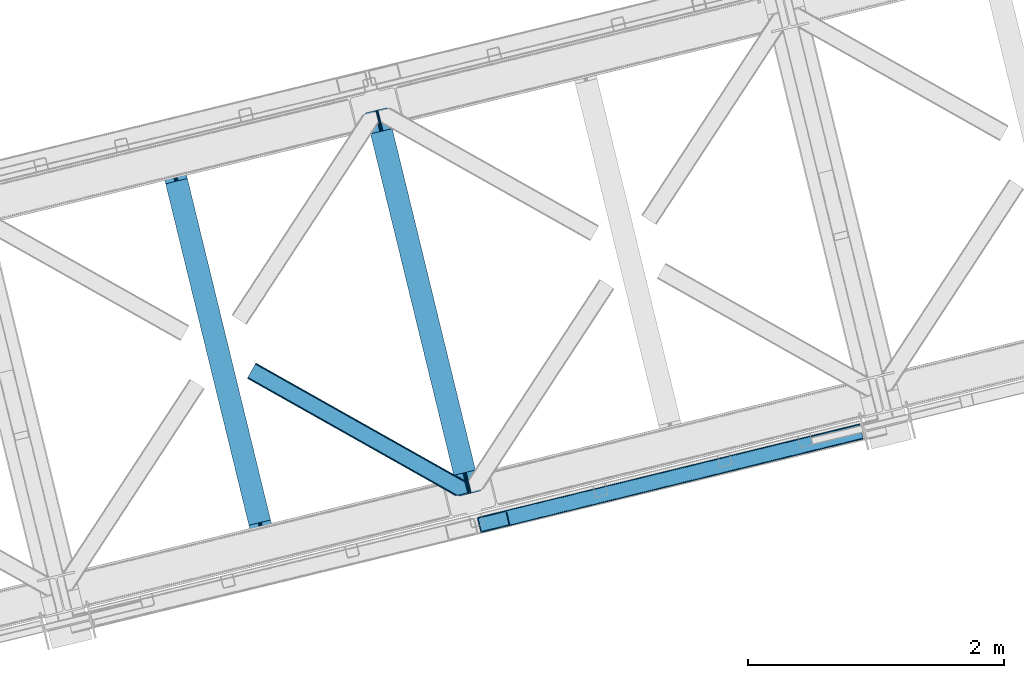
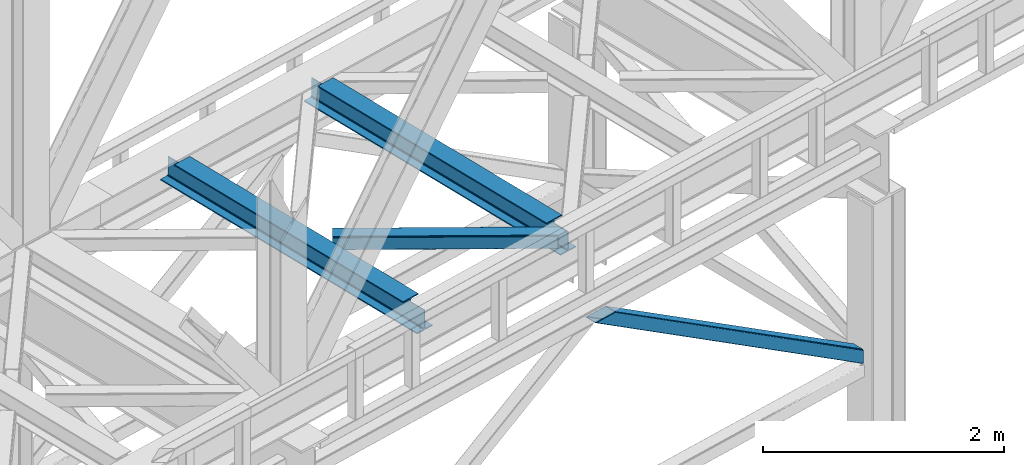
# One storey, part 46 of 93: 2 beams, 2 members.
"""IFC4 building model written with IfcOpenShell, lengths in millimetres."""

from ifc_helpers import new_model, entity, si_unit, converted_unit, derived_unit, direction, frame, origin, place, context, subcontext, project, spatial, triangles, polygons, material, type_object, element, save


model = new_model("IFC4")

# Units and contexts
model_context = context("Model", 3, precision=0.01, world=origin(), true_north=direction((6.12303176911189e-17, 1.0)))
plan_context = context("Plan", 3, precision=0.01, world=origin(), true_north=direction((6.12303176911189e-17, 1.0)))
body_context = subcontext(model_context, "Body", "Model", "MODEL_VIEW")
ifc_project = project(units=[si_unit("LENGTHUNIT", "METRE", prefix="MILLI"), si_unit("AREAUNIT", "SQUARE_METRE"), si_unit("VOLUMEUNIT", "CUBIC_METRE"), converted_unit("PLANEANGLEUNIT", "DEGREE", entity("IfcRatioMeasure", 0.0174532925199433), si_unit("PLANEANGLEUNIT", "RADIAN"), dimensions=[0, 0, 0, 0, 0, 0, 0]), si_unit("MASSUNIT", "GRAM", prefix="KILO"), derived_unit("MASSDENSITYUNIT", [(si_unit("MASSUNIT", "GRAM", prefix="KILO"), 1), (si_unit("LENGTHUNIT", "METRE"), -3)]), derived_unit("MOMENTOFINERTIAUNIT", [(si_unit("LENGTHUNIT", "METRE"), 4)]), si_unit("TIMEUNIT", "SECOND"), si_unit("FREQUENCYUNIT", "HERTZ"), si_unit("THERMODYNAMICTEMPERATUREUNIT", "DEGREE_CELSIUS"), derived_unit("THERMALTRANSMITTANCEUNIT", [(si_unit("MASSUNIT", "GRAM", prefix="KILO"), 1), (si_unit("THERMODYNAMICTEMPERATUREUNIT", "KELVIN"), -1), (si_unit("TIMEUNIT", "SECOND"), -3)]), derived_unit("VOLUMETRICFLOWRATEUNIT", [(si_unit("LENGTHUNIT", "METRE"), 3), (si_unit("TIMEUNIT", "SECOND"), -1)]), derived_unit("MASSFLOWRATEUNIT", [(si_unit("MASSUNIT", "GRAM", prefix="KILO"), 1), (si_unit("TIMEUNIT", "SECOND"), -1)]), derived_unit("ROTATIONALFREQUENCYUNIT", [(si_unit("TIMEUNIT", "SECOND"), -1)]), si_unit("ELECTRICCURRENTUNIT", "AMPERE"), si_unit("ELECTRICVOLTAGEUNIT", "VOLT"), si_unit("POWERUNIT", "WATT"), si_unit("FORCEUNIT", "NEWTON", prefix="KILO"), si_unit("ILLUMINANCEUNIT", "LUX"), si_unit("LUMINOUSFLUXUNIT", "LUMEN"), si_unit("LUMINOUSINTENSITYUNIT", "CANDELA"), derived_unit("USERDEFINED", [(si_unit("MASSUNIT", "GRAM", prefix="KILO"), -1), (si_unit("LENGTHUNIT", "METRE"), -2), (si_unit("TIMEUNIT", "SECOND"), 3), (si_unit("LUMINOUSFLUXUNIT", "LUMEN"), 1)]), derived_unit("LINEARVELOCITYUNIT", [(si_unit("LENGTHUNIT", "METRE"), 1), (si_unit("TIMEUNIT", "SECOND"), -1)]), si_unit("PRESSUREUNIT", "PASCAL"), derived_unit("USERDEFINED", [(si_unit("LENGTHUNIT", "METRE"), -2), (si_unit("MASSUNIT", "GRAM", prefix="KILO"), 1), (si_unit("TIMEUNIT", "SECOND"), -2)]), derived_unit("LINEARFORCEUNIT", [(si_unit("MASSUNIT", "GRAM", prefix="KILO"), 1), (si_unit("LENGTHUNIT", "METRE"), 1), (si_unit("TIMEUNIT", "SECOND"), -2), (si_unit("LENGTHUNIT", "METRE"), -1)]), derived_unit("PLANARFORCEUNIT", [(si_unit("MASSUNIT", "GRAM", prefix="KILO"), 1), (si_unit("LENGTHUNIT", "METRE"), 1), (si_unit("TIMEUNIT", "SECOND"), -2), (si_unit("LENGTHUNIT", "METRE"), -2)])], contexts=[model_context, plan_context])

# Site, building, storey
site_placement = place(None, origin())
site = spatial("IfcSite", under=ifc_project, at=site_placement, CompositionType="ELEMENT")
building_placement = place(site_placement, origin())
building = spatial("IfcBuilding", under=site, at=building_placement, CompositionType="ELEMENT")
storey_placement = place(building_placement, frame((0.0, 0.0, 15900.0)))
storey = spatial("IfcBuildingStorey", under=building, at=storey_placement, CompositionType="ELEMENT", Elevation=15900.0)

# Beams
ifc_material = material(Name="Metal painted (White)")
beam_type = type_object("IfcBeamType", PredefinedType="BEAM")
beam_1_placement = place(storey_placement, frame((-41419.287749643, 7690.31520751018, 3441.0)))
element("IfcBeam", 1, at=beam_1_placement, inside=storey, type_object=beam_type, material=ifc_material, ObjectType="Steel Beam", PredefinedType="BEAM", context=body_context, shape_type="Tessellation", body=[
    polygons([(900.98534618944, 41.4445662733081, 11.000000000004), (900.98534618944, 41.4445662733081, 2.16573425859679e-12), (170.021610174761, 3040.13999372697, 2.16573425859679e-12), (170.021610174761, 3040.13999372697, 11.000000000004), (834.919806235814, 25.3403919499645, 11.000000000004), (103.956070221135, 3024.03581940362, 11.000000000004), (828.971056214531, 23.8903211957396, 12.2179274798217), (98.0073201998513, 3022.5857486494, 12.2179274798217), (823.927949458422, 22.6610105689183, 15.6862915010192), (92.9642134437427, 3021.35643802258, 15.6862915010192), (820.558253255246, 21.8396114687108, 20.8770650821657), (89.5945172405668, 3020.53503892237, 20.8770650821657), (819.374973305552, 21.5511744621195, 27.0000000000047), (88.4112372908723, 3020.24660191578, 27.0000000000047), (81.6103728838888, 3018.58881926485, 27.0000000000047), (81.6103728838888, 3018.58881926485, 203.000000000006), (88.4112372908723, 3020.24660191578, 203.000000000006), (0.0, 2998.69542745366, 2.16573425859679e-12), (0.0, 2998.69542745366, 10.9999999999997), (66.0655399536259, 3014.799601777, 11.000000000004), (72.0142899749184, 3016.24967253123, 12.2179274798217), (77.057396731027, 3017.47898315805, 15.6862915010192), (80.4270929341942, 3018.30038225826, 20.8770650821613), (819.374973305543, 21.5511744621206, 203.000000000006), (812.574108898559, 19.8933918111876, 203.000000000006), (812.574108898559, 19.8933918111876, 27.0000000000047), (811.390828948873, 19.6049548045974, 20.8770650821613), (808.021132745689, 18.7835557043876, 15.6862915010192), (802.978025989589, 17.5542450775696, 12.2179274798217), (797.029275968296, 16.1041743233425, 11.000000000004), (730.963736014679, 0.0, 10.9999999999997), (730.963736014679, 0.0, 2.16573425859679e-12), (779.675212882749, 184.415062601693, 203.069791966819), (128.020401343512, 2857.75452019162, 203.000000000006), (128.243282132658, 2856.84017775719, 203.617301946336), (128.256196377177, 2856.7871977843, 217.000003693143), (779.530009633833, 185.010597404072, 217.000003676718), (779.530880241722, 185.007025963192, 204.00000679514), (772.96491171832, 182.385463974442, 203.006342981529), (772.742064056791, 183.299815969774, 203.617301946336), (772.729149812254, 183.352795942667, 217.000003693143), (121.455336555616, 2855.12939632289, 217.000003676718), (121.454465947718, 2855.13296776377, 204.00000679514), (121.310166358664, 2855.72494066435, 203.076120467494), (121.219536936511, 2856.09673754069, 203.000000000006), (780.713494357877, 185.298194377513, 223.122939328039), (784.082490766539, 186.122464201394, 228.313710402595), (789.125126170563, 187.353708426698, 231.782072735464), (795.073705041266, 188.804481281379, 232.999999602236), (861.13915590679, 204.909021065314, 232.999999283132), (861.137682570352, 204.915065042187, 243.999994005812), (691.116301666431, 163.469558245297, 243.999994827032), (691.117775002877, 163.463514268425, 233.000000104353), (757.183225868401, 179.568054052361, 232.999999785253), (763.132130996731, 181.017488520583, 231.782072861012), (768.175695503853, 182.244921343717, 228.313710479427), (771.546082413602, 183.063487001148, 223.12293937232), (120.271851831572, 2854.84179934945, 223.122939328039), (116.902855422901, 2854.01752952557, 228.313710402595), (111.860220018877, 2852.78628530027, 231.782072735464), (105.911641148165, 2851.33551244559, 232.999999602236), (39.8461902826505, 2835.23097266165, 232.999999283128), (39.8476636190881, 2835.22492868478, 243.999994005812), (209.869044523001, 2876.67043548167, 243.999994827032), (209.867571186572, 2876.67647945854, 233.000000104357), (143.802120321031, 2860.57193967461, 232.999999785253), (137.853215192718, 2859.12250520639, 231.782072861012), (132.809650685579, 2857.89507238325, 228.313710479427), (129.439263775847, 2857.07650672582, 223.12293937232)], [[[1, 2, 3, 4]], [[5, 1, 4, 6]], [[7, 5, 6, 8]], [[9, 7, 8, 10]], [[11, 9, 10, 12]], [[13, 11, 12, 14]], [[15, 16, 17, 14, 12, 10, 8, 6, 4, 3, 18, 19, 20, 21, 22, 23]], [[13, 24, 25, 26, 27, 28, 29, 30, 31, 32, 2, 1, 5, 7, 9, 11]], [[2, 32, 18, 3]], [[32, 31, 19, 18]], [[31, 30, 20, 19]], [[27, 26, 15, 23]], [[28, 27, 23, 22]], [[29, 28, 22, 21]], [[30, 29, 21, 20]], [[33, 24, 13, 14, 17, 34, 35, 36, 37, 38]], [[25, 39, 40, 41, 42, 43, 44, 16, 15, 26]], [[39, 25, 24, 33]], [[45, 34, 17, 16]], [[41, 40, 38, 37, 46, 47, 48, 49, 50, 51, 52, 53, 54, 55, 56, 57]], [[42, 58, 59, 60, 61, 62, 63, 64, 65, 66, 67, 68, 69, 36, 35, 43]], [[46, 37, 36, 69]], [[47, 46, 69, 68]], [[48, 47, 68, 67]], [[49, 48, 67, 66]], [[50, 49, 66, 65]], [[51, 50, 65, 64]], [[52, 51, 64, 63]], [[53, 52, 63, 62]], [[54, 53, 62, 61]], [[55, 54, 61, 60]], [[56, 55, 60, 59]], [[57, 56, 59, 58]], [[41, 57, 58, 42]]], closed=False),
])
beam_2_placement = place(storey_placement, frame((-39816.2268537096, 8081.07826094423, 3441.0)))
element("IfcBeam", 2, at=beam_2_placement, inside=storey, type_object=beam_type, material=ifc_material, ObjectType="Steel Beam", PredefinedType="BEAM", context=body_context, shape_type="Tessellation", body=[
    polygons([(900.98534618944, 41.4445662733081, 11.000000000004), (900.98534618944, 41.4445662733081, 2.16573425859679e-12), (170.02161017477, 3040.13999372697, 2.16573425859679e-12), (170.021610174761, 3040.13999372697, 11.000000000004), (834.919806235814, 25.3403919499656, 11.000000000004), (103.956070221135, 3024.03581940363, 11.000000000004), (828.971056214522, 23.8903211957385, 12.2179274798217), (98.0073201998427, 3022.5857486494, 12.2179274798217), (823.927949458418, 22.6610105689172, 15.6862915010192), (92.9642134437427, 3021.35643802258, 15.6862915010192), (820.558253255237, 21.8396114687097, 20.8770650821657), (89.5945172405581, 3020.53503892237, 20.8770650821657), (819.374973305552, 21.5511744621206, 27.0000000000047), (88.4112372908723, 3020.24660191578, 27.0000000000047), (81.6103728838888, 3018.58881926485, 27.0000000000047), (81.6103728838888, 3018.58881926485, 203.000000000006), (88.4112372908809, 3020.24660191578, 203.000000000006), (8.66293703438714e-12, 2998.69542745366, 2.16573425859679e-12), (8.66293703438714e-12, 2998.69542745366, 10.9999999999997), (66.0655399536259, 3014.799601777, 11.000000000004), (72.014289974927, 3016.24967253123, 12.2179274798217), (77.057396731027, 3017.47898315805, 15.6862915010192), (80.4270929342029, 3018.30038225826, 20.8770650821657), (819.374973305552, 21.5511744621206, 203.000000000006), (812.574108898564, 19.8933918111876, 203.000000000006), (812.574108898564, 19.8933918111876, 27.0000000000047), (811.390828948882, 19.6049548045974, 20.8770650821657), (808.021132745702, 18.7835557043898, 15.6862915010192), (802.978025989598, 17.5542450775685, 12.2179274798217), (797.029275968305, 16.1041743233425, 11.000000000004), (730.963736014688, 0.0, 10.9999999999997), (730.963736014688, 0.0, 2.16573425859679e-12), (779.675212882757, 184.415062601693, 203.069791966819), (128.020401343512, 2857.75452019162, 203.000000000006), (128.243282132658, 2856.84017775719, 203.617301946336), (128.256196377177, 2856.7871977843, 217.000003693143), (779.530009633833, 185.010597404072, 217.000003676718), (779.530880241722, 185.007025963192, 204.00000679514), (772.96491171832, 182.385463974442, 203.006342981529), (772.742064056782, 183.299815969774, 203.617301946336), (772.729149812263, 183.352795942667, 217.000003693143), (121.455336555608, 2855.1293963229, 217.000003676718), (121.454465947718, 2855.13296776378, 204.00000679514), (121.310166358664, 2855.72494066435, 203.076120467494), (121.21953693652, 2856.09673754069, 203.000000000006), (780.713494357868, 185.298194377513, 223.122939328039), (784.082490766539, 186.122464201392, 228.313710402595), (789.125126170563, 187.353708426696, 231.78207273546), (795.073705041266, 188.80448128138, 232.999999602236), (861.139155906794, 204.909021065314, 232.999999283132), (861.137682570357, 204.915065042187, 243.999994005812), (691.11630166644, 163.469558245297, 243.999994827032), (691.117775002877, 163.463514268423, 233.000000104353), (757.183225868401, 179.568054052359, 232.999999785253), (763.132130996739, 181.017488520583, 231.782072861012), (768.175695503862, 182.244921343715, 228.313710479427), (771.546082413611, 183.063487001148, 223.12293937232), (120.271851831572, 2854.84179934945, 223.122939328039), (116.902855422901, 2854.01752952557, 228.313710402595), (111.860220018886, 2852.78628530027, 231.782072735464), (105.911641148174, 2851.33551244559, 232.999999602236), (39.8461902826505, 2835.23097266165, 232.999999283128), (39.8476636190881, 2835.22492868478, 243.999994005812), (209.869044523001, 2876.67043548167, 243.999994827032), (209.867571186563, 2876.67647945854, 233.000000104357), (143.80212032104, 2860.57193967461, 232.999999785253), (137.85321519271, 2859.12250520638, 231.782072861007), (132.809650685579, 2857.89507238325, 228.313710479427), (129.439263775847, 2857.07650672582, 223.12293937232)], [[[1, 2, 3, 4]], [[5, 1, 4, 6]], [[7, 5, 6, 8]], [[9, 7, 8, 10]], [[11, 9, 10, 12]], [[13, 11, 12, 14]], [[15, 16, 17, 14, 12, 10, 8, 6, 4, 3, 18, 19, 20, 21, 22, 23]], [[13, 24, 25, 26, 27, 28, 29, 30, 31, 32, 2, 1, 5, 7, 9, 11]], [[2, 32, 18, 3]], [[32, 31, 19, 18]], [[31, 30, 20, 19]], [[27, 26, 15, 23]], [[28, 27, 23, 22]], [[29, 28, 22, 21]], [[30, 29, 21, 20]], [[33, 24, 13, 14, 17, 34, 35, 36, 37, 38]], [[25, 39, 40, 41, 42, 43, 44, 16, 15, 26]], [[39, 25, 24, 33]], [[45, 34, 17, 16]], [[41, 40, 38, 37, 46, 47, 48, 49, 50, 51, 52, 53, 54, 55, 56, 57]], [[42, 58, 59, 60, 61, 62, 63, 64, 65, 66, 67, 68, 69, 36, 35, 43]], [[46, 37, 36, 69]], [[47, 46, 69, 68]], [[48, 47, 68, 67]], [[49, 48, 67, 66]], [[50, 49, 66, 65]], [[51, 50, 65, 64]], [[52, 51, 64, 63]], [[53, 52, 63, 62]], [[54, 53, 62, 61]], [[55, 54, 61, 60]], [[56, 55, 60, 59]], [[57, 56, 59, 58]], [[41, 57, 58, 42]]], closed=False),
])

# Members
member_type_1 = type_object("IfcMemberType", PredefinedType="BRACE")
member_1_placement = place(storey_placement, frame((-38942.192779541, 7796.97931365967, 965.733325195311)))
element("IfcMember", 3, at=member_1_placement, inside=storey, type_object=member_type_1, ObjectType="Steel Vertical Brace", PredefinedType="BRACE", context=body_context, shape_type="Tessellation", body=[
    triangles([(2980.25064697266, 840.910299682618, 4.31950378417969), (3005.96535644531, 734.987113952638, 4.46135559082177), (0.0, 110.814166259765, 1902.27458496094), (25.9333007812456, 4.94446563720703, 1902.27458496094), (2993.26380615234, 851.573602294921, 0.777859497069585), (7.36001586914063, 120.226963806153, 1902.27458496094), (12.8666564941377, 122.203005981445, 1902.27458496094), (2986.92233276367, 848.369146728516, 1.96848449706886), (2993.30101318359, 851.416053771974, 0.0), (2.97888793945458, 117.368417358399, 1902.27458496094), (2993.08939819336, 852.292163085937, 4.33810729980542), (2981.60870361328, 844.395552062989, 3.70675048827979), (0.39532470703125, 114.063386535645, 1902.27458496094), (3022.51783447265, 731.559997558595, 0.863900756834482), (3022.69224243164, 730.848413085937, 4.42647399902489), (42.6090270996065, 0.792974853516171, 1902.27458496094), (36.8117065429688, 0.0, 1902.27458496094), (31.6073730468706, 0.510433959961119, 1902.27458496094), (3015.30432128906, 731.450701904297, 2.12545166015479), (3008.76518554687, 732.520985412598, 3.85674133300927), (27.7890014648438, 2.24695587158203, 1902.27458496094), (3022.48295288086, 731.707662963868, 0.126736450194585), (2993.08939819336, 852.292163085937, 132.50470275879), (214.121813964841, 171.505810546875, 1902.27458496094), (219.916809082031, 172.29878540039, 1902.27458496094), (2993.36612548828, 851.153860473633, 135.831243896486), (225.123468017577, 171.78835144043, 1902.27458496094), (2993.6428527832, 850.015557861328, 139.157785034178), (228.941839599611, 170.052410888672, 1902.27458496094), (2994.3125793457, 847.268051147462, 140.537933349609), (230.795214843747, 167.353738403321, 1902.27458496094), (2994.9823059082, 844.519963073731, 141.916918945313), (3020.79700927734, 738.620613098145, 141.994821166991), (256.730841064455, 61.484619140625, 1902.27458496094), (3021.46673583984, 735.872525024414, 140.619323730469), (3022.13646240234, 733.124436950683, 139.243826293947), (256.335516357423, 58.2353988647465, 1902.27458496094), (3022.41551513672, 731.986134338379, 135.918447875978), (253.749627685545, 54.9297866821289, 1902.27458496094), (3022.69224243164, 730.848413085937, 132.593069458009), (249.370825195314, 52.0724029541016, 1902.27458496094), (243.861859130855, 50.0957794189453, 1902.27458496094), (2994.85905761718, 840.371379089355, 0.32439880371021), (3018.68783569336, 742.221556091309, 0.455786132813955), (3020.39703369141, 740.26062927246, 0.11743469238354), (2995.40553588867, 842.7851852417, 0.00930175781104481), (8.33670043945313, 108.738130187989, 1902.27458496094), (32.3677917480454, 10.6388854980469, 1902.27458496094), (2994.7148803711, 845.623384094238, 3.0765563964851), (2994.18002929688, 847.814529418946, 5.44501647949073), (15.6967163085938, 118.150927734375, 1902.27458496094), (2995.25903320313, 843.389799499512, 0.662750244140625), (11.317913818355, 115.292381286621, 1902.27458496094), (8.73435058593896, 111.987350463867, 1902.27458496094), (2994.03585205078, 848.405772399902, 9.04363403320167), (21.2033569335908, 120.126969909668, 1902.27458496094), (34.2234924316363, 7.94137573242188, 1902.27458496094), (3020.55516357422, 739.609506225585, 0.589498901368643), (38.0395385742158, 6.20427246093732, 1902.27458496094), (3021.19000854492, 737.010827636718, 2.47426757812354), (43.2461975097613, 5.69441986083984, 1902.27458496094), (3021.46673583984, 735.872525024414, 5.80080871581958), (49.0435180664063, 6.48739471435601, 1902.27458496094), (3021.74346313476, 734.73422241211, 9.12734985351563), (2994.03585205078, 848.405772399902, 127.803826904295), (207.687322998048, 165.811390686035, 1902.27458496094), (2995.26135864258, 843.381660461427, 135.837057495119), (2995.93108520508, 840.633572387695, 137.216043090819), (224.360723876955, 161.659318542481, 1902.27458496094), (2994.59163208008, 846.129748535156, 134.456909179688), (222.507348632811, 164.357409667969, 1902.27458496094), (2994.3125793457, 847.268051147462, 131.130368041991), (218.688977050777, 166.09393157959, 1902.27458496094), (213.484643554686, 166.604946899414, 1902.27458496094), (247.996490478516, 60.3114349365233, 1902.27458496094), (248.391815185547, 63.5600738525391, 1902.27458496094), (235.525158691402, 52.1712341308594, 1902.27458496094), (245.412927246092, 57.0064041137693, 1902.27458496094), (241.034124755861, 54.1478576660156, 1902.27458496094), (3021.46673583984, 735.872525024414, 131.211758422851), (3021.74346313476, 734.73422241211, 127.887542724609), (3021.19000854492, 737.010827636718, 134.53713684082), (3020.52028198242, 739.758915710449, 135.912634277345), (3019.85055541992, 742.507003784181, 137.288131713867)], [[1, 2, 3], [4, 3, 2], [5, 6, 7], [6, 5, 8], [5, 9, 8], [8, 10, 6], [7, 11, 5], [8, 12, 10], [13, 10, 12], [12, 1, 13], [3, 13, 1], [14, 15, 16], [17, 18, 19], [19, 14, 17], [2, 20, 21], [21, 4, 2], [20, 19, 18], [18, 21, 20], [19, 22, 14], [16, 17, 14], [23, 11, 24], [7, 24, 11], [23, 24, 25], [26, 25, 27], [28, 27, 29], [30, 29, 31], [31, 32, 30], [29, 30, 28], [27, 28, 26], [25, 26, 23], [33, 32, 31], [31, 34, 33], [35, 33, 34], [36, 35, 37], [38, 36, 39], [40, 38, 41], [41, 42, 40], [39, 41, 38], [37, 39, 36], [34, 37, 35], [15, 40, 42], [42, 16, 15], [43, 44, 1], [45, 19, 44], [45, 22, 19], [46, 8, 9], [8, 46, 43], [43, 12, 8], [2, 44, 20], [20, 44, 19], [44, 2, 1], [43, 1, 12], [44, 43, 47], [47, 48, 44], [49, 50, 51], [52, 49, 53], [54, 47, 43], [43, 46, 54], [46, 52, 54], [53, 54, 52], [51, 53, 49], [50, 55, 56], [56, 51, 50], [57, 45, 44], [57, 58, 45], [45, 57, 59], [60, 59, 61], [62, 61, 63], [63, 64, 62], [61, 62, 60], [59, 60, 45], [44, 48, 57], [55, 65, 66], [66, 56, 55], [67, 68, 69], [70, 67, 71], [72, 70, 73], [65, 72, 74], [74, 66, 65], [73, 74, 72], [71, 73, 70], [69, 71, 67], [71, 27, 25], [69, 34, 31], [29, 71, 31], [71, 29, 27], [71, 69, 31], [73, 71, 25], [66, 24, 7], [24, 73, 25], [74, 24, 66], [74, 73, 24], [39, 75, 41], [76, 34, 69], [34, 75, 37], [75, 34, 76], [39, 37, 75], [42, 77, 16], [41, 75, 78], [78, 79, 42], [79, 77, 42], [42, 41, 78], [53, 6, 54], [7, 56, 66], [7, 51, 56], [53, 7, 6], [53, 51, 7], [47, 3, 4], [54, 6, 10], [13, 54, 10], [54, 13, 3], [47, 54, 3], [17, 59, 57], [16, 77, 63], [63, 61, 16], [61, 59, 16], [17, 16, 59], [18, 17, 57], [4, 48, 47], [57, 4, 21], [4, 57, 48], [21, 18, 57], [80, 40, 81], [15, 62, 64], [81, 40, 15], [22, 60, 15], [64, 81, 15], [62, 15, 60], [45, 60, 22], [80, 38, 40], [82, 35, 36], [38, 80, 82], [36, 38, 82], [83, 33, 35], [35, 82, 83], [33, 84, 32], [84, 33, 83], [65, 23, 72], [49, 9, 50], [52, 9, 49], [55, 23, 65], [11, 55, 50], [50, 9, 11], [55, 11, 23], [72, 26, 70], [67, 30, 32], [70, 30, 67], [68, 32, 84], [32, 68, 67], [70, 28, 30], [26, 72, 23], [26, 28, 70], [68, 84, 69], [76, 69, 84], [81, 77, 79], [80, 79, 78], [82, 78, 75], [83, 75, 76], [76, 84, 83], [75, 83, 82], [78, 82, 80], [79, 80, 81], [81, 64, 77], [63, 77, 64]]),
])
member_type_2 = type_object("IfcMemberType", PredefinedType="BRACE")
member_2_placement = place(storey_placement, frame((-40741.7410766602, 8083.99609680176, 3511.0000579834)))
element("IfcMember", 4, at=member_2_placement, inside=storey, type_object=member_type_2, ObjectType="Steel Horizontal Brace", PredefinedType="BRACE", context=body_context, shape_type="Tessellation", body=[
    triangles([(1645.8111694336, 3.74570159912037, 138.667117309571), (1655.3361694336, 6.06765289306622, 139.999594116212), (8.58552246094041, 933.436628723144, 139.999594116212), (5.29735107422312, 927.60151977539, 138.667117309571), (1637.73724365234, 1.7772171020506, 134.874325561526), (2.511474609375, 922.654147338866, 134.874325561526), (1632.34222412109, 0.462181091308594, 129.197927856447), (0.651123046875, 919.349116516112, 129.197927856447), (1630.44466552735, 0.0, 122.500662231447), (0.0, 918.188722229004, 122.500662231447), (1630.44466552735, 0.0, 17.5000946044929), (0.0, 918.188722229004, 17.5000946044929), (1706.56560058594, 97.7219421386717, 139.999594116212), (1724.78309326172, 22.9956893920898, 139.999594116212), (60.1079589843794, 1024.92639312744, 139.999594116212), (1701.3240600586, 119.229931640624, 129.197927856447), (1700.89152832032, 121.001916503907, 122.500662231447), (68.0423583984375, 1039.01448669434, 129.197927856447), (68.6934814453125, 1040.17488098145, 122.500662231447), (1702.55654296876, 114.183146667479, 134.874325561526), (66.1773559570356, 1035.70887451172, 134.874325561526), (1704.39829101563, 106.630700683593, 138.667117309571), (63.3961303710967, 1030.76208343506, 138.667117309571), (1700.89152832032, 121.001916503907, 17.5000946044929), (68.6934814453125, 1040.17488098145, 17.5000946044929), (0.651123046875, 919.349116516112, 10.8028289794929), (1633.02590332032, 0.628450012206486, 10.9377044677749), (2.511474609375, 922.654147338866, 5.12526855468968), (5.29735107422312, 927.60151977539, 1.33247680664135), (1569.79720458985, 46.5552978515625, 1.33247680664135), (1573.68999023438, 34.810665893554, 8.52041015625218), (1571.51337890625, 39.5190994262693, 5.59500732422021), (1572.28542480469, 36.3408050537109, 7.52047119140843), (1573.34582519531, 35.1809921264648, 8.278564453125), (1572.98770751953, 35.5757354736324, 8.02044067383031), (1572.62493896484, 35.9698974609373, 7.76231689453198), (1633.97468261719, 0.859831237792605, 8.52041015625218), (1567.62524414063, 55.464056396484, 0.0), (8.58552246094041, 933.436628723144, 0.0), (1533.57615966797, 195.143321228026, 0.0), (60.1079589843794, 1024.92639312744, 0.0), (1566.72762451172, 59.1423202514643, 7.52047119140843), (1567.24387207031, 57.3435928344725, 7.90300598144677), (1567.77872314453, 56.4360900878901, 8.1076446533225), (1568.32287597656, 55.5210296630858, 8.31460876464917), (1568.41124267579, 55.3774337768555, 8.3471649169951), (1568.86237792969, 54.6135269165034, 8.52041015625218), (1655.14548339844, 6.02114410400372, 8.52041015625218), (5.94847412109812, 928.753775024414, 12.1260040283232), (1647.69477539063, 4.20439453124982, 12.1260040283232), (8.73435058593896, 933.700566101073, 8.3320495605476), (12.0178710937544, 939.535675048828, 6.99957275390625), (1565.35561523438, 64.7762786865233, 6.99957275390625), (1642.29975585938, 2.88935852050781, 17.8035644531265), (4.08812255859812, 925.448162841796, 17.8035644531265), (1640.40219726563, 2.42717742919922, 24.4996673583992), (3.43234863281396, 924.287768554686, 24.4996673583992), (1640.40219726563, 2.42717742919922, 115.501089477541), (3.43234863281396, 924.287768554686, 115.501089477541), (1647.69477539063, 4.20439453124982, 127.87475280762), (1655.76870117188, 6.17287902831958, 131.667544555665), (1642.29975585938, 2.88935852050781, 122.196029663086), (1665.29370117188, 8.49483032226544, 133.000021362306), (1724.78309326172, 22.9956893920898, 133.000021362306), (4.08812255859812, 925.448162841796, 122.196029663086), (5.94847412109812, 928.753775024414, 127.87475280762), (8.73435058593896, 933.700566101073, 131.667544555665), (12.0178710937544, 939.535675048828, 133.000021362306), (1708.8398803711, 88.4097198486324, 133.000021362306), (56.6709594726563, 1018.82734680176, 133.000021362306), (1535.84578857422, 185.831680297852, 6.99957275390625), (56.6709594726563, 1018.82734680176, 6.99957275390625), (68.0423583984375, 1039.01448669434, 10.8028289794929), (62.7450073242217, 1029.60924682617, 12.1260040283232), (64.6053588867217, 1032.91485900879, 17.8035644531265), (65.2611328125058, 1034.07583465576, 24.4996673583992), (66.1773559570356, 1035.70887451172, 5.12526855468968), (63.3961303710967, 1030.76208343506, 1.33247680664135), (59.9591308593808, 1024.66245574951, 8.3320495605476), (62.7450073242217, 1029.60924682617, 127.87475280762), (65.2611328125058, 1034.07583465576, 115.501089477541), (64.6053588867217, 1032.91485900879, 122.196029663086), (59.9591308593808, 1024.66245574951, 131.667544555665), (1703.16115722657, 111.689694213866, 24.4996673583992), (1703.16115722657, 111.689694213866, 115.501089477541), (1706.66791992188, 97.3190597534176, 131.667544555665), (1704.826171875, 104.871505737305, 127.87475280762), (1703.59368896484, 109.917709350586, 122.196029663086), (1704.826171875, 104.871505737305, 12.1260040283232), (1706.52374267578, 97.9004196166989, 8.52041015625218), (1701.6961303711, 117.703280639647, 8.52041015625218), (1703.59368896484, 109.917709350586, 17.8035644531265), (1701.48218994141, 118.591017150879, 10.9365417480476), (1534.47377929688, 191.465638732911, 7.52047119140843), (1529.68802490235, 211.088859558105, 5.59500732422021), (1528.91597900391, 214.266572570801, 7.52047119140843), (1531.40419921876, 204.05207977295, 1.33247680664135), (1529.11131591797, 214.689802551269, 8.22740478515698), (1529.01364746094, 214.478187561035, 7.87393798828271), (1529.89731445313, 214.453189086913, 8.52041015625218), (1534.34820556641, 192.706260681152, 7.85649719238427), (1534.72492675782, 194.650328063964, 8.52041015625218)], [[1, 2, 3], [3, 4, 1], [5, 1, 4], [4, 6, 5], [7, 5, 6], [6, 8, 7], [9, 7, 8], [8, 10, 9], [11, 9, 10], [10, 12, 11], [2, 13, 3], [2, 14, 13], [15, 3, 13], [16, 17, 18], [19, 18, 17], [20, 16, 21], [18, 21, 16], [22, 20, 23], [21, 23, 20], [13, 22, 15], [23, 15, 22], [17, 24, 19], [25, 19, 24], [26, 27, 11], [28, 29, 30], [27, 26, 31], [26, 28, 32], [32, 33, 26], [34, 26, 35], [34, 31, 26], [26, 36, 35], [26, 33, 36], [31, 37, 27], [30, 32, 28], [38, 30, 29], [29, 39, 38], [11, 12, 26], [40, 38, 39], [39, 41, 40], [33, 42, 43], [36, 43, 44], [35, 44, 45], [34, 46, 47], [34, 45, 46], [47, 31, 34], [45, 34, 35], [44, 35, 36], [43, 36, 33], [48, 37, 47], [31, 47, 37], [49, 50, 47], [47, 51, 49], [47, 46, 51], [50, 48, 47], [52, 43, 42], [51, 46, 45], [45, 52, 51], [45, 44, 52], [43, 52, 44], [42, 53, 52], [54, 50, 49], [49, 55, 54], [56, 54, 55], [55, 57, 56], [58, 56, 57], [57, 59, 58], [60, 61, 1], [5, 60, 1], [5, 7, 62], [60, 5, 62], [62, 7, 9], [61, 2, 1], [14, 63, 64], [14, 2, 63], [61, 63, 2], [62, 9, 58], [56, 11, 54], [9, 56, 58], [11, 27, 54], [9, 11, 56], [37, 54, 27], [50, 54, 37], [48, 50, 37], [62, 58, 65], [59, 65, 58], [60, 62, 66], [65, 66, 62], [61, 60, 67], [66, 67, 60], [63, 61, 68], [67, 68, 61], [69, 63, 68], [63, 69, 64], [68, 70, 69], [53, 71, 52], [72, 52, 71], [73, 74, 75], [76, 19, 25], [73, 75, 25], [73, 77, 74], [75, 76, 25], [74, 77, 78], [72, 41, 39], [41, 79, 78], [79, 41, 72], [79, 74, 78], [18, 80, 21], [81, 19, 76], [19, 82, 18], [82, 19, 81], [18, 82, 80], [15, 70, 3], [23, 21, 80], [80, 83, 23], [83, 70, 15], [15, 23, 83], [49, 29, 28], [39, 52, 72], [39, 51, 52], [51, 39, 29], [49, 51, 29], [57, 12, 10], [26, 55, 49], [28, 26, 49], [55, 26, 12], [57, 55, 12], [4, 66, 6], [3, 70, 68], [68, 67, 3], [67, 66, 4], [4, 3, 67], [8, 6, 66], [10, 59, 57], [65, 10, 8], [10, 65, 59], [65, 8, 66], [84, 85, 76], [81, 76, 85], [86, 69, 70], [70, 83, 86], [87, 86, 83], [83, 80, 87], [88, 87, 80], [80, 82, 88], [85, 88, 82], [82, 81, 85], [87, 20, 22], [89, 90, 91], [20, 87, 88], [86, 87, 22], [86, 13, 69], [14, 69, 13], [69, 14, 64], [86, 22, 13], [24, 17, 84], [91, 92, 89], [92, 24, 84], [93, 92, 91], [93, 24, 92], [17, 85, 84], [88, 16, 20], [17, 16, 88], [85, 17, 88], [40, 71, 53], [94, 95, 96], [40, 94, 71], [94, 97, 95], [94, 40, 97], [38, 40, 53], [42, 38, 53], [32, 42, 33], [42, 30, 38], [42, 32, 30], [73, 25, 24], [98, 99, 77], [96, 77, 99], [96, 95, 77], [73, 93, 100], [100, 77, 73], [100, 98, 77], [93, 91, 100], [78, 77, 95], [97, 40, 41], [41, 78, 97], [95, 97, 78], [24, 93, 73], [72, 71, 94], [94, 79, 72], [101, 102, 79], [79, 94, 101], [74, 79, 102], [90, 89, 102], [74, 102, 89], [92, 84, 75], [76, 75, 84], [89, 92, 74], [75, 74, 92], [101, 94, 99], [102, 101, 99], [91, 90, 102], [102, 100, 91]]),
])

save(model, "model.ifc")
